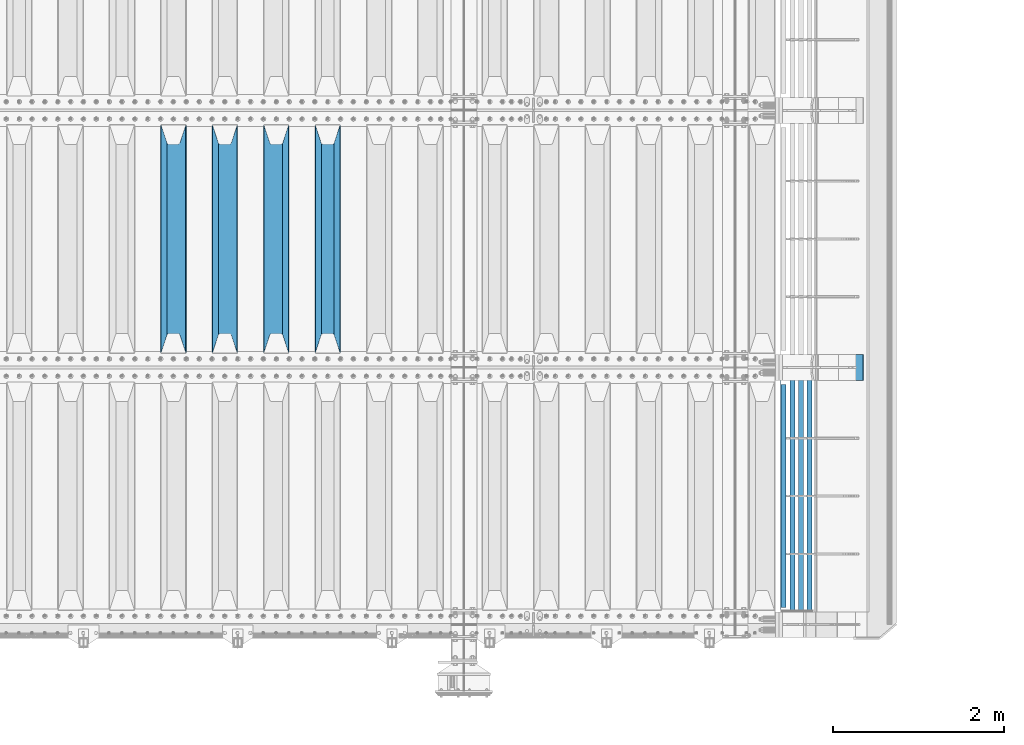
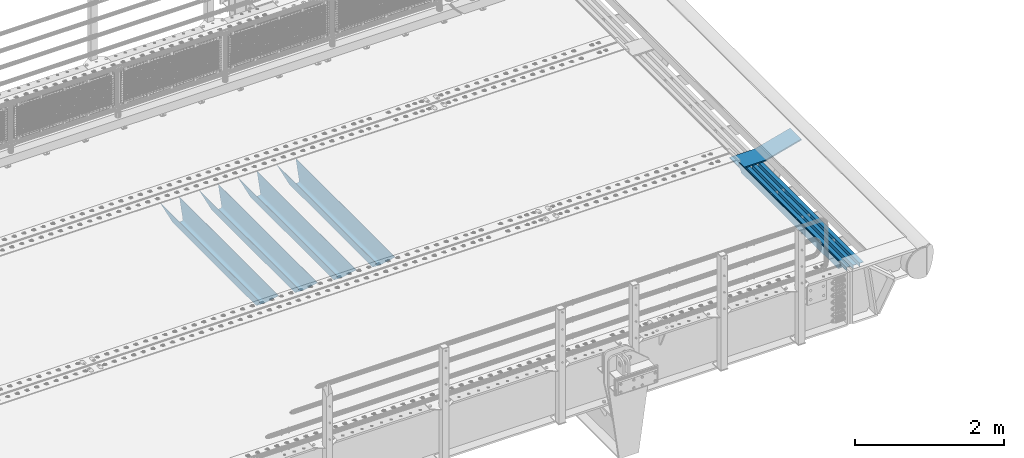
# One storey, part 105 of 219: 9 beams.
"""IFC2X3 building model written with IfcOpenShell, lengths in millimetres."""

from ifc_helpers import new_model, si_unit, frame, origin_with_axes, place, context, subcontext, project, spatial, faceted_brep, material, type_object, element, save


model = new_model("IFC2X3")

# Units and contexts
model_context = context("Model", 3, precision=1e-05, world=origin_with_axes())
body_context = subcontext(model_context, "Body", "Model", "MODEL_VIEW")
ifc_project = project(units=[si_unit("LENGTHUNIT", "METRE", prefix="MILLI"), si_unit("AREAUNIT", "SQUARE_METRE"), si_unit("VOLUMEUNIT", "CUBIC_METRE"), si_unit("MASSUNIT", "GRAM", prefix="KILO"), si_unit("TIMEUNIT", "SECOND"), si_unit("PLANEANGLEUNIT", "RADIAN"), si_unit("SOLIDANGLEUNIT", "STERADIAN"), si_unit("THERMODYNAMICTEMPERATUREUNIT", "DEGREE_CELSIUS"), si_unit("LUMINOUSINTENSITYUNIT", "LUMEN")], contexts=[model_context])

# Site, building, storey
site_placement = place(None, origin_with_axes())
site = spatial("IfcSite", under=ifc_project, at=site_placement, CompositionType="ELEMENT")
building_placement = place(site_placement, origin_with_axes())
building = spatial("IfcBuilding", under=site, at=building_placement, Name="Standard", CompositionType="ELEMENT")
storey_placement = place(building_placement, origin_with_axes())
storey = spatial("IfcBuildingStorey", under=building, at=storey_placement, Name="Undefined", CompositionType="ELEMENT", Elevation=0.0)

# Beams
ifc_material_1 = material(Name="STEEL/S355N")
beam_type_1 = type_object("IfcBeamType", PredefinedType="NOTDEFINED")
beam_1_placement = place(storey_placement, frame((8800.0, 27175.0, -115.0), z_axis=(0.0, 0.0, 1.0), x_axis=(0.0, 1.0, 0.0)))
element("IfcBeam", 1, at=beam_1_placement, inside=storey, type_object=beam_type_1, material=ifc_material_1, context=body_context, shape_type="Brep", body=[
    faceted_brep([(0.0, 150.0, 115.0), (0.0, 143.690000000001, 115.0), (2650.00000000297, 143.690000000001, 115.0), (2650.00000000297, 150.0, 115.0), (2650.00000000297, 142.0595652184, 110.000000003094), (2650.00000000297, 148.3695652184, 110.000000003094), (2441.90079219209, -80.110360073113, -98.0992078077845), (2437.7588105432, -77.5672621345566, -102.241189456673), (2434.06523489747, -74.4080125315541, -105.934765102404), (2430.9108609509, -70.7102721255742, -109.089139048974), (2428.37322971128, -66.5649389910068, -111.626770288588), (2426.51472138055, -62.0739139532889, -113.485278619323), (2425.38102192092, -57.3475956567672, -114.618978078955), (2424.99999999988, -52.5021667386536, -115.0), (2424.99999999988, 52.5021667386536, -115.0), (2425.38102192092, 57.3475956567672, -114.618978078955), (2426.51472138055, 62.0739139532889, -113.485278619323), (2428.37322971128, 66.5649389910068, -111.626770288588), (2430.9108609509, 70.7102721255742, -109.089139048974), (2434.06523489747, 74.4080125315541, -105.934765102404), (2437.7588105432, 77.5672621345566, -102.241189456673), (2441.90079219209, 80.110360073113, -98.0992078077846), (2446.38936140512, 81.9747917625791, -93.6106385947584), (2448.2494850041, 76.2713538057269, -91.7505149957729), (2444.62967112263, 74.7677798626082, -95.3703288772456), (2441.28936334127, 72.7168944282894, -98.710636658607), (2438.31067330439, 70.1691124903828, -101.689326695487), (2435.76682334748, 67.1870637758839, -104.233176652398), (2433.72034654134, 63.8440531834913, -106.279653458539), (2432.22154950042, 60.2222587982342, -107.778450499454), (2431.30727574265, 56.4107117849107, -108.692724257221), (2430.99999999987, 52.5031078186894, -109.0), (2430.99999999987, -52.5031078186894, -109.0), (2431.30727574265, -56.4107117849107, -108.692724257221), (2432.22154950042, -60.2222587982342, -107.778450499454), (2433.72034654134, -63.8440531834913, -106.279653458539), (2435.76682334748, -67.1870637758839, -104.233176652398), (2438.31067330439, -70.1691124903828, -101.689326695487), (2441.28936334127, -72.7168944282894, -98.7106366586071), (2444.62967112263, -74.7677798626082, -95.3703288772457), (2448.2494850041, -76.2713538057269, -91.7505149957729), (2650.00000000297, -142.0595652184, 110.000000003094), (2650.00000000297, -148.3695652184, 110.000000003094), (2446.38936140512, -81.9747917625791, -93.6106385947584), (2650.00000000297, -143.690000000001, 115.0), (2650.00000000297, -150.0, 115.0), (0.0, -143.690000000001, 115.0), (0.0, -150.0, 115.0), (0.0, -148.369565218261, 110.000000002667), (203.610638597427, -81.9747917625791, -93.6106385947584), (208.09920781045, -80.110360073113, -98.0992078077845), (212.241189459342, -77.5672621345566, -102.241189456673), (215.93476510507, -74.4080125315541, -105.934765102404), (219.089139051641, -70.7102721255742, -109.089139048974), (221.626770291256, -66.5649389910068, -111.626770288588), (223.485278621989, -62.0739139532889, -113.485278619323), (224.618978081624, -57.3475956567672, -114.618978078955), (225.000000002663, -52.5021667386536, -115.0), (225.000000002663, 52.5021667386536, -115.0), (224.618978081624, 57.3475956567672, -114.618978078955), (223.485278621989, 62.0739139532889, -113.485278619323), (221.626770291256, 66.5649389910068, -111.626770288588), (219.089139051641, 70.7102721255742, -109.089139048974), (215.93476510507, 74.4080125315541, -105.934765102404), (212.241189459342, 77.5672621345566, -102.241189456673), (208.09920781045, 80.110360073113, -98.0992078077846), (203.610638597427, 81.9747917625791, -93.6106385947584), (0.0, 148.369565218261, 110.000000002667), (0.0, 142.059565218262, 110.000000002667), (201.750514998439, 76.2713538057269, -91.7505149957729), (205.370328879915, 74.7677798626082, -95.3703288772456), (208.710636661275, 72.7168944282894, -98.710636658607), (211.689326698157, 70.1691124903828, -101.689326695487), (214.233176655063, 67.1870637758839, -104.233176652398), (216.279653461206, 63.8440531834913, -106.279653458539), (217.778450502123, 60.2222587982342, -107.778450499454), (218.69272425989, 56.4107117849107, -108.692724257221), (219.00000000267, 52.5031078186894, -109.0), (219.00000000267, -52.5031078186894, -109.0), (218.69272425989, -56.4107117849107, -108.692724257221), (217.778450502123, -60.2222587982342, -107.778450499454), (216.279653461206, -63.8440531834913, -106.279653458539), (214.233176655063, -67.1870637758839, -104.233176652398), (211.689326698157, -70.1691124903828, -101.689326695487), (208.710636661275, -72.7168944282894, -98.7106366586071), (205.370328879915, -74.7677798626082, -95.3703288772457), (201.750514998439, -76.2713538057269, -91.7505149957729), (0.0, -142.059565218262, 110.000000002667)], [[[0, 1, 2, 3]], [[3, 2, 4, 5]], [[6, 7, 8, 9, 10, 11, 12, 13, 14, 15, 16, 17, 18, 19, 20, 21, 22, 5, 4, 23, 24, 25, 26, 27, 28, 29, 30, 31, 32, 33, 34, 35, 36, 37, 38, 39, 40, 41, 42, 43]], [[44, 45, 42, 41]], [[46, 47, 45, 44]], [[43, 42, 45, 47, 48, 49]], [[6, 43, 49, 50]], [[7, 6, 50, 51]], [[8, 7, 51, 52]], [[9, 8, 52, 53]], [[10, 9, 53, 54]], [[11, 10, 54, 55]], [[12, 11, 55, 56]], [[13, 12, 56, 57]], [[14, 13, 57, 58]], [[15, 14, 58, 59]], [[16, 15, 59, 60]], [[17, 16, 60, 61]], [[18, 17, 61, 62]], [[19, 18, 62, 63]], [[20, 19, 63, 64]], [[21, 20, 64, 65]], [[22, 21, 65, 66]], [[0, 3, 5, 22, 66, 67]], [[1, 0, 67, 68]], [[23, 4, 2, 1, 68, 69]], [[24, 23, 69, 70]], [[25, 24, 70, 71]], [[26, 25, 71, 72]], [[27, 26, 72, 73]], [[28, 27, 73, 74]], [[29, 28, 74, 75]], [[30, 29, 75, 76]], [[31, 30, 76, 77]], [[32, 31, 77, 78]], [[33, 32, 78, 79]], [[34, 33, 79, 80]], [[35, 34, 80, 81]], [[36, 35, 81, 82]], [[37, 36, 82, 83]], [[38, 37, 83, 84]], [[39, 38, 84, 85]], [[40, 39, 85, 86]], [[46, 44, 41, 40, 86, 87]], [[47, 46, 87, 48]], [[86, 85, 84, 83, 82, 81, 80, 79, 78, 77, 76, 75, 74, 73, 72, 71, 70, 69, 68, 67, 66, 65, 64, 63, 62, 61, 60, 59, 58, 57, 56, 55, 54, 53, 52, 51, 50, 49, 48, 87]]]),
])
beam_2_placement = place(storey_placement, frame((8200.0, 27175.0, -115.0), z_axis=(0.0, 0.0, 1.0), x_axis=(0.0, 1.0, 0.0)))
element("IfcBeam", 2, at=beam_2_placement, inside=storey, type_object=beam_type_1, material=ifc_material_1, context=body_context, shape_type="Brep", body=[
    faceted_brep([(0.0, 150.0, 115.0), (0.0, 143.690000000001, 115.0), (2650.00000000297, 143.690000000001, 115.0), (2650.00000000297, 150.0, 115.0), (2650.00000000297, 142.0595652184, 110.000000003094), (2650.00000000297, 148.3695652184, 110.000000003094), (2441.90079219209, -80.110360073113, -98.0992078077845), (2437.7588105432, -77.5672621345566, -102.241189456673), (2434.06523489747, -74.4080125315541, -105.934765102404), (2430.9108609509, -70.7102721255742, -109.089139048974), (2428.37322971128, -66.5649389910068, -111.626770288588), (2426.51472138055, -62.0739139532889, -113.485278619323), (2425.38102192092, -57.3475956567672, -114.618978078955), (2424.99999999988, -52.5021667386536, -115.0), (2424.99999999988, 52.5021667386536, -115.0), (2425.38102192092, 57.3475956567672, -114.618978078955), (2426.51472138055, 62.0739139532889, -113.485278619323), (2428.37322971128, 66.5649389910068, -111.626770288588), (2430.9108609509, 70.7102721255742, -109.089139048974), (2434.06523489747, 74.4080125315541, -105.934765102404), (2437.7588105432, 77.5672621345566, -102.241189456673), (2441.90079219209, 80.110360073113, -98.0992078077846), (2446.38936140512, 81.9747917625791, -93.6106385947584), (2448.2494850041, 76.2713538057269, -91.7505149957729), (2444.62967112263, 74.7677798626082, -95.3703288772456), (2441.28936334127, 72.7168944282894, -98.710636658607), (2438.31067330439, 70.1691124903828, -101.689326695487), (2435.76682334748, 67.1870637758839, -104.233176652398), (2433.72034654134, 63.8440531834913, -106.279653458539), (2432.22154950042, 60.2222587982342, -107.778450499454), (2431.30727574265, 56.4107117849107, -108.692724257221), (2430.99999999987, 52.5031078186894, -109.0), (2430.99999999987, -52.5031078186894, -109.0), (2431.30727574265, -56.4107117849107, -108.692724257221), (2432.22154950042, -60.2222587982342, -107.778450499454), (2433.72034654134, -63.8440531834913, -106.279653458539), (2435.76682334748, -67.1870637758839, -104.233176652398), (2438.31067330439, -70.1691124903828, -101.689326695487), (2441.28936334127, -72.7168944282894, -98.7106366586071), (2444.62967112263, -74.7677798626082, -95.3703288772457), (2448.2494850041, -76.2713538057269, -91.7505149957729), (2650.00000000297, -142.0595652184, 110.000000003094), (2650.00000000297, -148.3695652184, 110.000000003094), (2446.38936140512, -81.9747917625791, -93.6106385947584), (2650.00000000297, -143.690000000001, 115.0), (2650.00000000297, -150.0, 115.0), (0.0, -143.690000000001, 115.0), (0.0, -150.0, 115.0), (0.0, -148.369565218261, 110.000000002667), (203.610638597427, -81.9747917625791, -93.6106385947584), (208.09920781045, -80.110360073113, -98.0992078077845), (212.241189459342, -77.5672621345566, -102.241189456673), (215.93476510507, -74.4080125315541, -105.934765102404), (219.089139051641, -70.7102721255742, -109.089139048974), (221.626770291256, -66.5649389910068, -111.626770288588), (223.485278621989, -62.0739139532889, -113.485278619323), (224.618978081624, -57.3475956567672, -114.618978078955), (225.000000002663, -52.5021667386536, -115.0), (225.000000002663, 52.5021667386536, -115.0), (224.618978081624, 57.3475956567672, -114.618978078955), (223.485278621989, 62.0739139532889, -113.485278619323), (221.626770291256, 66.5649389910068, -111.626770288588), (219.089139051641, 70.7102721255742, -109.089139048974), (215.93476510507, 74.4080125315541, -105.934765102404), (212.241189459342, 77.5672621345566, -102.241189456673), (208.09920781045, 80.110360073113, -98.0992078077846), (203.610638597427, 81.9747917625791, -93.6106385947584), (0.0, 148.369565218261, 110.000000002667), (0.0, 142.059565218262, 110.000000002667), (201.750514998439, 76.2713538057269, -91.7505149957729), (205.370328879915, 74.7677798626082, -95.3703288772456), (208.710636661275, 72.7168944282894, -98.710636658607), (211.689326698157, 70.1691124903828, -101.689326695487), (214.233176655063, 67.1870637758839, -104.233176652398), (216.279653461206, 63.8440531834913, -106.279653458539), (217.778450502123, 60.2222587982342, -107.778450499454), (218.69272425989, 56.4107117849107, -108.692724257221), (219.00000000267, 52.5031078186894, -109.0), (219.00000000267, -52.5031078186894, -109.0), (218.69272425989, -56.4107117849107, -108.692724257221), (217.778450502123, -60.2222587982342, -107.778450499454), (216.279653461206, -63.8440531834913, -106.279653458539), (214.233176655063, -67.1870637758839, -104.233176652398), (211.689326698157, -70.1691124903828, -101.689326695487), (208.710636661275, -72.7168944282894, -98.7106366586071), (205.370328879915, -74.7677798626082, -95.3703288772457), (201.750514998439, -76.2713538057269, -91.7505149957729), (0.0, -142.059565218262, 110.000000002667)], [[[0, 1, 2, 3]], [[3, 2, 4, 5]], [[6, 7, 8, 9, 10, 11, 12, 13, 14, 15, 16, 17, 18, 19, 20, 21, 22, 5, 4, 23, 24, 25, 26, 27, 28, 29, 30, 31, 32, 33, 34, 35, 36, 37, 38, 39, 40, 41, 42, 43]], [[44, 45, 42, 41]], [[46, 47, 45, 44]], [[43, 42, 45, 47, 48, 49]], [[6, 43, 49, 50]], [[7, 6, 50, 51]], [[8, 7, 51, 52]], [[9, 8, 52, 53]], [[10, 9, 53, 54]], [[11, 10, 54, 55]], [[12, 11, 55, 56]], [[13, 12, 56, 57]], [[14, 13, 57, 58]], [[15, 14, 58, 59]], [[16, 15, 59, 60]], [[17, 16, 60, 61]], [[18, 17, 61, 62]], [[19, 18, 62, 63]], [[20, 19, 63, 64]], [[21, 20, 64, 65]], [[22, 21, 65, 66]], [[0, 3, 5, 22, 66, 67]], [[1, 0, 67, 68]], [[23, 4, 2, 1, 68, 69]], [[24, 23, 69, 70]], [[25, 24, 70, 71]], [[26, 25, 71, 72]], [[27, 26, 72, 73]], [[28, 27, 73, 74]], [[29, 28, 74, 75]], [[30, 29, 75, 76]], [[31, 30, 76, 77]], [[32, 31, 77, 78]], [[33, 32, 78, 79]], [[34, 33, 79, 80]], [[35, 34, 80, 81]], [[36, 35, 81, 82]], [[37, 36, 82, 83]], [[38, 37, 83, 84]], [[39, 38, 84, 85]], [[40, 39, 85, 86]], [[46, 44, 41, 40, 86, 87]], [[47, 46, 87, 48]], [[86, 85, 84, 83, 82, 81, 80, 79, 78, 77, 76, 75, 74, 73, 72, 71, 70, 69, 68, 67, 66, 65, 64, 63, 62, 61, 60, 59, 58, 57, 56, 55, 54, 53, 52, 51, 50, 49, 48, 87]]]),
])
beam_3_placement = place(storey_placement, frame((7600.0, 27175.0, -115.0), z_axis=(0.0, 0.0, 1.0), x_axis=(0.0, 1.0, 0.0)))
element("IfcBeam", 3, at=beam_3_placement, inside=storey, type_object=beam_type_1, material=ifc_material_1, context=body_context, shape_type="Brep", body=[
    faceted_brep([(0.0, 150.0, 115.0), (0.0, 143.690000000001, 115.0), (2650.00000000297, 143.690000000001, 115.0), (2650.00000000297, 150.0, 115.0), (2650.00000000297, 142.0595652184, 110.000000003094), (2650.00000000297, 148.3695652184, 110.000000003094), (2441.90079219209, -80.110360073113, -98.0992078077845), (2437.7588105432, -77.5672621345566, -102.241189456673), (2434.06523489747, -74.4080125315541, -105.934765102404), (2430.9108609509, -70.7102721255742, -109.089139048974), (2428.37322971128, -66.5649389910068, -111.626770288588), (2426.51472138055, -62.0739139532889, -113.485278619323), (2425.38102192092, -57.3475956567672, -114.618978078955), (2424.99999999988, -52.5021667386536, -115.0), (2424.99999999988, 52.5021667386536, -115.0), (2425.38102192092, 57.3475956567672, -114.618978078955), (2426.51472138055, 62.0739139532889, -113.485278619323), (2428.37322971128, 66.5649389910068, -111.626770288588), (2430.9108609509, 70.7102721255742, -109.089139048974), (2434.06523489747, 74.4080125315541, -105.934765102404), (2437.7588105432, 77.5672621345566, -102.241189456673), (2441.90079219209, 80.110360073113, -98.0992078077846), (2446.38936140512, 81.9747917625791, -93.6106385947584), (2448.2494850041, 76.2713538057269, -91.7505149957729), (2444.62967112263, 74.7677798626082, -95.3703288772456), (2441.28936334127, 72.7168944282894, -98.710636658607), (2438.31067330439, 70.1691124903828, -101.689326695487), (2435.76682334748, 67.1870637758839, -104.233176652398), (2433.72034654134, 63.8440531834913, -106.279653458539), (2432.22154950042, 60.2222587982342, -107.778450499454), (2431.30727574265, 56.4107117849107, -108.692724257221), (2430.99999999987, 52.5031078186894, -109.0), (2430.99999999987, -52.5031078186894, -109.0), (2431.30727574265, -56.4107117849107, -108.692724257221), (2432.22154950042, -60.2222587982342, -107.778450499454), (2433.72034654134, -63.8440531834913, -106.279653458539), (2435.76682334748, -67.1870637758839, -104.233176652398), (2438.31067330439, -70.1691124903828, -101.689326695487), (2441.28936334127, -72.7168944282894, -98.7106366586071), (2444.62967112263, -74.7677798626082, -95.3703288772457), (2448.2494850041, -76.2713538057269, -91.7505149957729), (2650.00000000297, -142.0595652184, 110.000000003094), (2650.00000000297, -148.3695652184, 110.000000003094), (2446.38936140512, -81.9747917625791, -93.6106385947584), (2650.00000000297, -143.690000000001, 115.0), (2650.00000000297, -150.0, 115.0), (0.0, -143.690000000001, 115.0), (0.0, -150.0, 115.0), (0.0, -148.369565218261, 110.000000002667), (203.610638597427, -81.9747917625791, -93.6106385947584), (208.09920781045, -80.110360073113, -98.0992078077845), (212.241189459342, -77.5672621345566, -102.241189456673), (215.93476510507, -74.4080125315541, -105.934765102404), (219.089139051641, -70.7102721255742, -109.089139048974), (221.626770291256, -66.5649389910068, -111.626770288588), (223.485278621989, -62.0739139532889, -113.485278619323), (224.618978081624, -57.3475956567672, -114.618978078955), (225.000000002663, -52.5021667386536, -115.0), (225.000000002663, 52.5021667386536, -115.0), (224.618978081624, 57.3475956567672, -114.618978078955), (223.485278621989, 62.0739139532889, -113.485278619323), (221.626770291256, 66.5649389910068, -111.626770288588), (219.089139051641, 70.7102721255742, -109.089139048974), (215.93476510507, 74.4080125315541, -105.934765102404), (212.241189459342, 77.5672621345566, -102.241189456673), (208.09920781045, 80.110360073113, -98.0992078077846), (203.610638597427, 81.9747917625791, -93.6106385947584), (0.0, 148.369565218261, 110.000000002667), (0.0, 142.059565218262, 110.000000002667), (201.750514998439, 76.2713538057269, -91.7505149957729), (205.370328879915, 74.7677798626082, -95.3703288772456), (208.710636661275, 72.7168944282894, -98.710636658607), (211.689326698157, 70.1691124903828, -101.689326695487), (214.233176655063, 67.1870637758839, -104.233176652398), (216.279653461206, 63.8440531834913, -106.279653458539), (217.778450502123, 60.2222587982342, -107.778450499454), (218.69272425989, 56.4107117849107, -108.692724257221), (219.00000000267, 52.5031078186894, -109.0), (219.00000000267, -52.5031078186894, -109.0), (218.69272425989, -56.4107117849107, -108.692724257221), (217.778450502123, -60.2222587982342, -107.778450499454), (216.279653461206, -63.8440531834913, -106.279653458539), (214.233176655063, -67.1870637758839, -104.233176652398), (211.689326698157, -70.1691124903828, -101.689326695487), (208.710636661275, -72.7168944282894, -98.7106366586071), (205.370328879915, -74.7677798626082, -95.3703288772457), (201.750514998439, -76.2713538057269, -91.7505149957729), (0.0, -142.059565218262, 110.000000002667)], [[[0, 1, 2, 3]], [[3, 2, 4, 5]], [[6, 7, 8, 9, 10, 11, 12, 13, 14, 15, 16, 17, 18, 19, 20, 21, 22, 5, 4, 23, 24, 25, 26, 27, 28, 29, 30, 31, 32, 33, 34, 35, 36, 37, 38, 39, 40, 41, 42, 43]], [[44, 45, 42, 41]], [[46, 47, 45, 44]], [[43, 42, 45, 47, 48, 49]], [[6, 43, 49, 50]], [[7, 6, 50, 51]], [[8, 7, 51, 52]], [[9, 8, 52, 53]], [[10, 9, 53, 54]], [[11, 10, 54, 55]], [[12, 11, 55, 56]], [[13, 12, 56, 57]], [[14, 13, 57, 58]], [[15, 14, 58, 59]], [[16, 15, 59, 60]], [[17, 16, 60, 61]], [[18, 17, 61, 62]], [[19, 18, 62, 63]], [[20, 19, 63, 64]], [[21, 20, 64, 65]], [[22, 21, 65, 66]], [[0, 3, 5, 22, 66, 67]], [[1, 0, 67, 68]], [[23, 4, 2, 1, 68, 69]], [[24, 23, 69, 70]], [[25, 24, 70, 71]], [[26, 25, 71, 72]], [[27, 26, 72, 73]], [[28, 27, 73, 74]], [[29, 28, 74, 75]], [[30, 29, 75, 76]], [[31, 30, 76, 77]], [[32, 31, 77, 78]], [[33, 32, 78, 79]], [[34, 33, 79, 80]], [[35, 34, 80, 81]], [[36, 35, 81, 82]], [[37, 36, 82, 83]], [[38, 37, 83, 84]], [[39, 38, 84, 85]], [[40, 39, 85, 86]], [[46, 44, 41, 40, 86, 87]], [[47, 46, 87, 48]], [[86, 85, 84, 83, 82, 81, 80, 79, 78, 77, 76, 75, 74, 73, 72, 71, 70, 69, 68, 67, 66, 65, 64, 63, 62, 61, 60, 59, 58, 57, 56, 55, 54, 53, 52, 51, 50, 49, 48, 87]]]),
])
beam_4_placement = place(storey_placement, frame((7000.0, 27175.0, -115.0), z_axis=(0.0, 0.0, 1.0), x_axis=(0.0, 1.0, 0.0)))
element("IfcBeam", 4, at=beam_4_placement, inside=storey, type_object=beam_type_1, material=ifc_material_1, context=body_context, shape_type="Brep", body=[
    faceted_brep([(0.0, 150.0, 115.0), (0.0, 143.690000000001, 115.0), (2650.00000000297, 143.690000000001, 115.0), (2650.00000000297, 150.0, 115.0), (2650.00000000297, 142.0595652184, 110.000000003094), (2650.00000000297, 148.3695652184, 110.000000003094), (2441.90079219209, -80.110360073113, -98.0992078077845), (2437.7588105432, -77.5672621345566, -102.241189456673), (2434.06523489747, -74.4080125315541, -105.934765102404), (2430.9108609509, -70.7102721255742, -109.089139048974), (2428.37322971128, -66.5649389910068, -111.626770288588), (2426.51472138055, -62.0739139532889, -113.485278619323), (2425.38102192092, -57.3475956567672, -114.618978078955), (2424.99999999988, -52.5021667386536, -115.0), (2424.99999999988, 52.5021667386536, -115.0), (2425.38102192092, 57.3475956567672, -114.618978078955), (2426.51472138055, 62.0739139532889, -113.485278619323), (2428.37322971128, 66.5649389910068, -111.626770288588), (2430.9108609509, 70.7102721255742, -109.089139048974), (2434.06523489747, 74.4080125315541, -105.934765102404), (2437.7588105432, 77.5672621345566, -102.241189456673), (2441.90079219209, 80.110360073113, -98.0992078077846), (2446.38936140512, 81.9747917625791, -93.6106385947584), (2448.2494850041, 76.2713538057269, -91.7505149957729), (2444.62967112263, 74.7677798626082, -95.3703288772456), (2441.28936334127, 72.7168944282894, -98.710636658607), (2438.31067330439, 70.1691124903828, -101.689326695487), (2435.76682334748, 67.1870637758839, -104.233176652398), (2433.72034654134, 63.8440531834913, -106.279653458539), (2432.22154950042, 60.2222587982342, -107.778450499454), (2431.30727574265, 56.4107117849107, -108.692724257221), (2430.99999999987, 52.5031078186894, -109.0), (2430.99999999987, -52.5031078186894, -109.0), (2431.30727574265, -56.4107117849107, -108.692724257221), (2432.22154950042, -60.2222587982342, -107.778450499454), (2433.72034654134, -63.8440531834913, -106.279653458539), (2435.76682334748, -67.1870637758839, -104.233176652398), (2438.31067330439, -70.1691124903828, -101.689326695487), (2441.28936334127, -72.7168944282894, -98.7106366586071), (2444.62967112263, -74.7677798626082, -95.3703288772457), (2448.2494850041, -76.2713538057269, -91.7505149957729), (2650.00000000297, -142.0595652184, 110.000000003094), (2650.00000000297, -148.3695652184, 110.000000003094), (2446.38936140512, -81.9747917625791, -93.6106385947584), (2650.00000000297, -143.690000000001, 115.0), (2650.00000000297, -150.0, 115.0), (0.0, -143.690000000001, 115.0), (0.0, -150.0, 115.0), (0.0, -148.369565218261, 110.000000002667), (203.610638597427, -81.9747917625791, -93.6106385947584), (208.09920781045, -80.110360073113, -98.0992078077845), (212.241189459342, -77.5672621345566, -102.241189456673), (215.93476510507, -74.4080125315541, -105.934765102404), (219.089139051641, -70.7102721255742, -109.089139048974), (221.626770291256, -66.5649389910068, -111.626770288588), (223.485278621989, -62.0739139532889, -113.485278619323), (224.618978081624, -57.3475956567672, -114.618978078955), (225.000000002663, -52.5021667386536, -115.0), (225.000000002663, 52.5021667386536, -115.0), (224.618978081624, 57.3475956567672, -114.618978078955), (223.485278621989, 62.0739139532889, -113.485278619323), (221.626770291256, 66.5649389910068, -111.626770288588), (219.089139051641, 70.7102721255742, -109.089139048974), (215.93476510507, 74.4080125315541, -105.934765102404), (212.241189459342, 77.5672621345566, -102.241189456673), (208.09920781045, 80.110360073113, -98.0992078077846), (203.610638597427, 81.9747917625791, -93.6106385947584), (0.0, 148.369565218261, 110.000000002667), (0.0, 142.059565218262, 110.000000002667), (201.750514998439, 76.2713538057269, -91.7505149957729), (205.370328879915, 74.7677798626082, -95.3703288772456), (208.710636661275, 72.7168944282894, -98.710636658607), (211.689326698157, 70.1691124903828, -101.689326695487), (214.233176655063, 67.1870637758839, -104.233176652398), (216.279653461206, 63.8440531834913, -106.279653458539), (217.778450502123, 60.2222587982342, -107.778450499454), (218.69272425989, 56.4107117849107, -108.692724257221), (219.00000000267, 52.5031078186894, -109.0), (219.00000000267, -52.5031078186894, -109.0), (218.69272425989, -56.4107117849107, -108.692724257221), (217.778450502123, -60.2222587982342, -107.778450499454), (216.279653461206, -63.8440531834913, -106.279653458539), (214.233176655063, -67.1870637758839, -104.233176652398), (211.689326698157, -70.1691124903828, -101.689326695487), (208.710636661275, -72.7168944282894, -98.7106366586071), (205.370328879915, -74.7677798626082, -95.3703288772457), (201.750514998439, -76.2713538057269, -91.7505149957729), (0.0, -142.059565218262, 110.000000002667)], [[[0, 1, 2, 3]], [[3, 2, 4, 5]], [[6, 7, 8, 9, 10, 11, 12, 13, 14, 15, 16, 17, 18, 19, 20, 21, 22, 5, 4, 23, 24, 25, 26, 27, 28, 29, 30, 31, 32, 33, 34, 35, 36, 37, 38, 39, 40, 41, 42, 43]], [[44, 45, 42, 41]], [[46, 47, 45, 44]], [[43, 42, 45, 47, 48, 49]], [[6, 43, 49, 50]], [[7, 6, 50, 51]], [[8, 7, 51, 52]], [[9, 8, 52, 53]], [[10, 9, 53, 54]], [[11, 10, 54, 55]], [[12, 11, 55, 56]], [[13, 12, 56, 57]], [[14, 13, 57, 58]], [[15, 14, 58, 59]], [[16, 15, 59, 60]], [[17, 16, 60, 61]], [[18, 17, 61, 62]], [[19, 18, 62, 63]], [[20, 19, 63, 64]], [[21, 20, 64, 65]], [[22, 21, 65, 66]], [[0, 3, 5, 22, 66, 67]], [[1, 0, 67, 68]], [[23, 4, 2, 1, 68, 69]], [[24, 23, 69, 70]], [[25, 24, 70, 71]], [[26, 25, 71, 72]], [[27, 26, 72, 73]], [[28, 27, 73, 74]], [[29, 28, 74, 75]], [[30, 29, 75, 76]], [[31, 30, 76, 77]], [[32, 31, 77, 78]], [[33, 32, 78, 79]], [[34, 33, 79, 80]], [[35, 34, 80, 81]], [[36, 35, 81, 82]], [[37, 36, 82, 83]], [[38, 37, 83, 84]], [[39, 38, 84, 85]], [[40, 39, 85, 86]], [[46, 44, 41, 40, 86, 87]], [[47, 46, 87, 48]], [[86, 85, 84, 83, 82, 81, 80, 79, 78, 77, 76, 75, 74, 73, 72, 71, 70, 69, 68, 67, 66, 65, 64, 63, 62, 61, 60, 59, 58, 57, 56, 55, 54, 53, 52, 51, 50, 49, 48, 87]]]),
])
ifc_material_2 = material(Name="STEEL/S355J2")
beam_type_2 = type_object("IfcBeamType", PredefinedType="NOTDEFINED")
beam_5_placement = place(storey_placement, frame((14114.5025260065, 24150.0, -124.999999999977), z_axis=(0.0, 0.0, 1.0), x_axis=(0.0, 1.0, 0.0)))
element("IfcBeam", 5, at=beam_5_placement, inside=storey, type_object=beam_type_2, material=ifc_material_2, context=body_context, shape_type="Brep", body=[
    faceted_brep([(2700.0, 22.5, -15.0), (2684.54915028125, 22.5000000000018, -17.4471741852423), (2684.54915028125, 32.5, -17.4471741852423), (2700.0, 32.5, -15.0), (2670.61073738538, 22.5000000000018, -24.5491502812526), (2670.61073738538, 32.5, -24.5491502812526), (2659.54915028125, 22.5000000000018, -35.6107373853764), (2659.54915028125, 32.5, -35.6107373853764), (2652.44717418524, 22.5000000000018, -49.5491502812526), (2652.44717418524, 32.5, -49.5491502812526), (2651.58384440325, -32.5, -55.0), (2650.0, -32.5, -65.0), (2650.0, 32.5, -65.0), (2651.58384440325, 22.5, -55.0), (0.0, 32.5, 65.0), (0.0, 22.5, 65.0), (2700.0, 22.5, 65.0), (2700.0, 32.5, 65.0), (0.0, 32.5, -15.0), (0.0, 22.5, -15.0), (15.4508497187489, 32.5, -17.4471741852423), (15.4508497187489, 22.5, -17.4471741852423), (29.3892626146226, 32.5, -24.5491502812526), (29.3892626146226, 22.5, -24.5491502812526), (40.4508497187489, 32.5, -35.6107373853763), (40.4508497187489, 22.5, -35.6107373853763), (47.5528258147569, 32.5, -49.5491502812526), (47.5528258147569, 22.5, -49.5491502812526), (50.0, -32.5, -65.0), (48.4161555967512, -32.5, -55.0), (48.4161555967512, 22.5, -55.0), (50.0, 32.5, -65.0)], [[[0, 1, 2, 3]], [[4, 5, 2, 1]], [[6, 7, 5, 4]], [[8, 9, 7, 6]], [[10, 11, 12, 9, 8, 13]], [[14, 15, 16, 17]], [[15, 14, 18, 19]], [[19, 18, 20, 21]], [[21, 20, 22, 23]], [[23, 22, 24, 25]], [[25, 24, 26, 27]], [[28, 29, 30, 27, 26, 31]], [[30, 29, 10, 13]], [[16, 15, 19, 21, 23, 25, 27, 30, 13, 8, 6, 4, 1, 0]], [[17, 16, 0, 3]], [[5, 7, 9, 12, 31, 26, 24, 22, 20, 18, 14, 17, 3, 2]], [[28, 31, 12, 11]], [[29, 28, 11, 10]]]),
])
beam_type_3 = type_object("IfcBeamType", PredefinedType="NOTDEFINED")
beam_6_placement = place(storey_placement, frame((14106.9988298906, 27000.0, -169.999999999995), z_axis=(0.0, -1.0, 0.0), x_axis=(1.0, 0.0, 0.0)))
element("IfcBeam", 6, at=beam_6_placement, inside=storey, type_object=beam_type_3, material=ifc_material_1, context=body_context, shape_type="Brep", body=[
    faceted_brep([(0.0, 10.0, -150.0), (0.0, 10.0, 150.0), (356.495387467725, 10.0, 150.0), (356.495387467727, 9.99999999999903, -150.0), (0.0, -10.0, 150.0), (0.0, -10.0, -150.0), (356.495387467725, -10.0, -150.0), (356.495387467725, -10.0, 150.0), (382.770279632496, 11.7334369044542, 150.0), (382.770279632496, 11.7334369044542, -150.0), (385.397768848972, -8.0932194051, -150.0), (385.397768848972, -8.0932194051, 150.0), (413.799145685096, -2.40593045896915, -150.0), (413.799145685096, -2.40593045896915, 150.0), (408.589713119878, 16.9036995827554, 150.0), (408.589713119874, 16.9036995827009, -150.0), (938.999999999996, 160.0, 150.0), (938.999999999996, 160.0, -150.0), (944.209432565211, 140.69036995827, 150.0), (944.209432565211, 140.69036995827, -150.0)], [[[0, 1, 2, 3]], [[4, 5, 6, 7]], [[5, 4, 1, 0]], [[3, 2, 8, 9]], [[7, 6, 10, 11]], [[10, 12, 13, 11]], [[8, 14, 15, 9]], [[15, 14, 16, 17]], [[14, 8, 2, 1, 4, 7, 11, 13, 18, 16]], [[13, 12, 19, 18]], [[12, 10, 6, 5, 0, 3, 9, 15, 17, 19]], [[18, 19, 17, 16]]]),
])
beam_type_4 = type_object("IfcBeamType", PredefinedType="NOTDEFINED")
for number, where, z_axis, x_axis in (
    (7, (14422.0024147167, 26869.9999976591, -210.000211453654), (0.0, 0.0, -1.0), (0.0, -1.0, 0.0)),
    (8, (14322.0024147167, 26869.9999976591, -210.000211453654), (0.0, 0.0, -1.0), (0.0, -1.0, 0.0)),
    (9, (14222.002414716, 26869.9999976591, -210.000211453713), (0.0, 0.0, -1.0), (0.0, -1.0, 0.0)),
):
    element("IfcBeam", number, at=place(storey_placement, frame(where, z_axis=z_axis, x_axis=x_axis)), inside=storey, type_object=beam_type_4, material=ifc_material_2, context=body_context, shape_type="Brep", body=[
        faceted_brep([(3.63797880709171e-12, 29.9999999999982, -30.0), (0.0, 29.9999999999982, 30.0), (2710.00000000001, 29.9999999999982, 30.0), (2710.00000000001, 29.9999999999982, -30.0), (0.0, 23.9999999999982, 30.0), (2710.00000000001, 23.9999999999982, 30.0), (0.0, 23.9999999999982, -24.0), (2710.00000000001, 23.9999999999982, -24.0), (3.63797880709171e-12, -30.0000000000018, -24.0), (2710.00000000001, -30.0000000000018, -24.0), (3.63797880709171e-12, -30.0000000000018, -30.0), (2710.00000000001, -30.0000000000018, -30.0)], [[[0, 1, 2, 3]], [[1, 4, 5, 2]], [[4, 6, 7, 5]], [[6, 8, 9, 7]], [[8, 10, 11, 9]], [[10, 0, 3, 11]], [[5, 7, 9, 11, 3, 2]], [[10, 8, 6, 4, 1, 0]]]),
    ])

save(model, "model.ifc")
